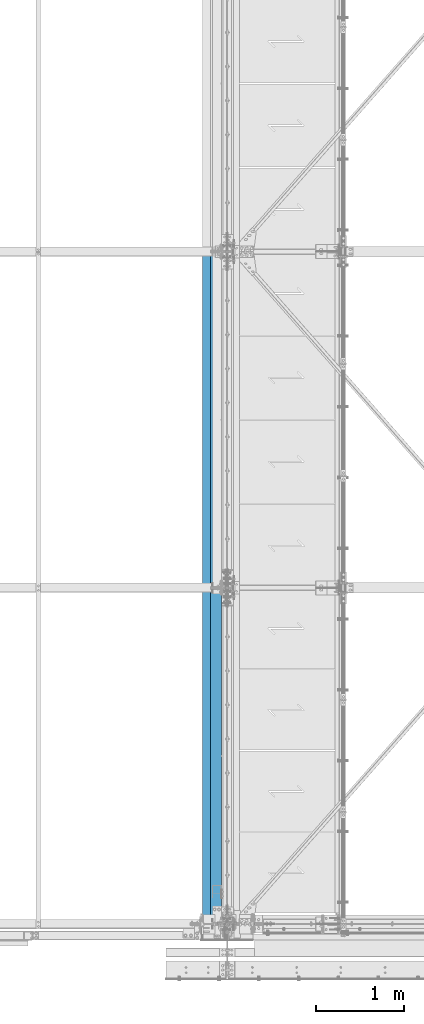
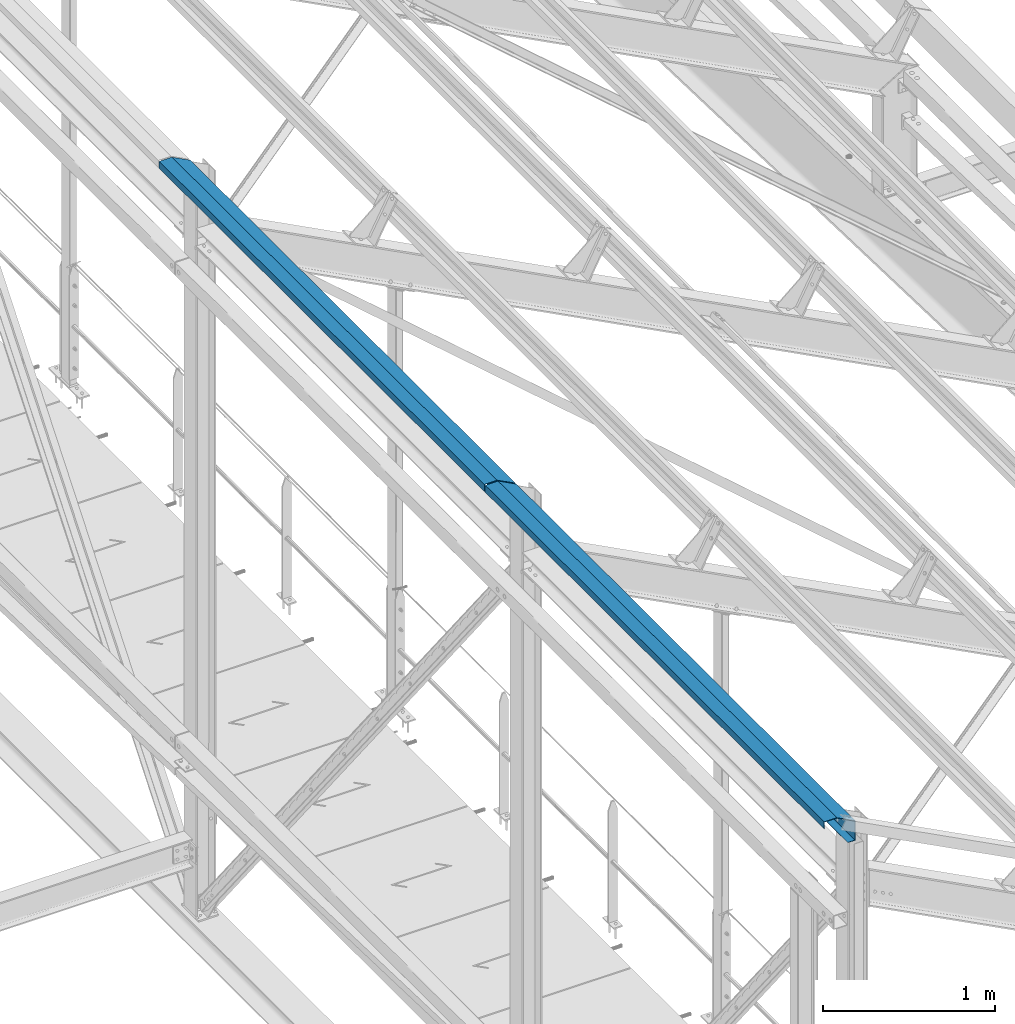
# One storey, part 344 of 496: 2 beams, 2 elements without a shape of their own.
"""IFC2X3 building model written with IfcOpenShell, lengths in millimetres."""

from ifc_helpers import new_model, si_unit, frame, origin_with_axes, place, context, subcontext, project, spatial, faceted_brep, material, type_object, element, aggregate, save


model = new_model("IFC2X3")

# Units and contexts
model_context = context("Model", 3, precision=1e-05, world=origin_with_axes())
body_context = subcontext(model_context, "Body", "Model", "MODEL_VIEW")
ifc_project = project(units=[si_unit("LENGTHUNIT", "METRE", prefix="MILLI"), si_unit("AREAUNIT", "SQUARE_METRE"), si_unit("VOLUMEUNIT", "CUBIC_METRE"), si_unit("MASSUNIT", "GRAM", prefix="KILO"), si_unit("TIMEUNIT", "SECOND"), si_unit("PLANEANGLEUNIT", "RADIAN"), si_unit("SOLIDANGLEUNIT", "STERADIAN"), si_unit("THERMODYNAMICTEMPERATUREUNIT", "DEGREE_CELSIUS"), si_unit("LUMINOUSINTENSITYUNIT", "LUMEN")], contexts=[model_context])

# Site, building, storey
site_placement = place(None, origin_with_axes())
site = spatial("IfcSite", under=ifc_project, at=site_placement, CompositionType="ELEMENT")
building_placement = place(site_placement, origin_with_axes())
building = spatial("IfcBuilding", under=site, at=building_placement, Name="Undefined", CompositionType="ELEMENT")
storey_placement = place(building_placement, origin_with_axes())
storey = spatial("IfcBuildingStorey", under=building, at=storey_placement, Name="Undefined", CompositionType="ELEMENT", Elevation=0.0)

# Assembly, beam
assembly_1_placement = place(storey_placement, origin_with_axes())
assembly_1 = element("IfcElementAssembly", 1, at=assembly_1_placement, inside=storey, Name="SHED", AssemblyPlace="NOTDEFINED", PredefinedType="NOTDEFINED")
ifc_material = material(Name="Undefined/S235-E24")
beam_type_1 = type_object("IfcBeamType", PredefinedType="NOTDEFINED")
beam_1_placement = place(assembly_1_placement, frame((12404.99999895, 5699.99999584194, 12628.7260697644), z_axis=(0.0, 1.0, 0.0), x_axis=(0.0, 0.0, 1.0)))
beam_1 = element("IfcBeam", 2, at=beam_1_placement, type_object=beam_type_1, material=ifc_material, Name="SHED", context=body_context, shape_type="Brep", body=[
    faceted_brep([(-3.49427864421159e-08, -1.49999999999636, -1895.0), (-3.52956703864038e-08, -1.5, 1895.0), (3.49573383573443e-08, 1.5, 1895.0), (3.53102223016322e-08, 1.5, -1895.0), (47.0000011861484, 1.499998899395, 1895.0), (47.0000011898519, 1.49999889939863, -1895.0), (50.0000011927114, -1.50000117085074, -1895.0), (50.0000011890152, -1.50000117085438, 1895.0), (47.0, 83.711228987213, 1895.0), (47.0, 83.711228987213, -1895.0), (50.0, 84.4485168457013, -1895.0), (50.0, 84.4485168457013, 1895.0), (-16.7103107286657, 205.5, 1895.0), (-16.7103107286657, 205.5, -1895.0), (-14.8939838409424, 208.5, -1895.0), (-14.8939838409424, 208.5, 1895.0), (-151.893997192383, 205.5, 1895.0), (-151.893997192383, 205.5, -1895.0), (-154.893997192383, 208.5, -1895.0), (-154.893997192383, 208.5, 1895.0), (-151.893997192383, 158.5, 1895.0), (-151.893997192383, 158.5, -1895.0), (-154.893997192383, 158.5, 1895.0), (-154.893997192383, 158.5, -1895.0)], [[[0, 1, 2, 3]], [[3, 2, 4, 5]], [[1, 0, 6, 7]], [[5, 4, 8, 9]], [[7, 6, 10, 11]], [[9, 8, 12, 13]], [[11, 10, 14, 15]], [[13, 12, 16, 17]], [[15, 14, 18, 19]], [[17, 16, 20, 21]], [[16, 12, 8, 4, 2, 1, 7, 11, 15, 19, 22, 20]], [[19, 18, 23, 22]], [[18, 14, 10, 6, 0, 3, 5, 9, 13, 17, 21, 23]], [[22, 23, 21, 20]]]),
])
aggregate(assembly_1, [beam_1])

assembly_2_placement = place(storey_placement, origin_with_axes())
assembly_2 = element("IfcElementAssembly", 3, at=assembly_2_placement, inside=storey, Name="SHED", AssemblyPlace="NOTDEFINED", PredefinedType="NOTDEFINED")
beam_type_2 = type_object("IfcBeamType", PredefinedType="NOTDEFINED")
beam_2_placement = place(assembly_2_placement, frame((12404.99999895, 1819.99999584194, 12628.7260697675), z_axis=(0.0, -1.0, 0.0), x_axis=(0.0, 0.0, 1.0)))
beam_2 = element("IfcBeam", 4, at=beam_2_placement, type_object=beam_type_2, material=ifc_material, Name="SHED", context=body_context, shape_type="Brep", body=[
    faceted_brep([(-4.57293936051428e-09, -1.5, -1975.0), (-2.82670953311026e-09, -1.49999999999636, 1975.0), (4.57293936051428e-09, 1.50000000000364, 1975.0), (2.82307155430317e-09, 1.50000000000364, -1975.0), (50.0, 1.5, 1975.0), (50.0, 1.5, -1975.0), (47.0, -1.5, -1975.0), (47.0, -1.5, 1975.0), (50.0, -84.4485168457013, 1975.0), (50.0, -84.4485168457013, -1975.0), (47.0, -83.711228987213, -1975.0), (47.0, -83.711228987213, 1975.0), (-14.8939838409424, -208.5, 1975.0), (-14.8939838409424, -208.5, -1975.0), (-16.7103107286657, -205.5, -1975.0), (-16.7103107286657, -205.5, 1975.0), (-154.893997192383, -208.5, 1975.0), (-154.893997192383, -208.5, -1975.0), (-151.893997192383, -205.5, -1975.0), (-151.893997192383, -205.5, 1975.0), (-154.893997192383, -158.5, 1975.0), (-154.893997192383, -158.5, -1975.0), (-151.893997192383, -158.5, 1975.0), (-151.893997192383, -158.5, -1975.0)], [[[0, 1, 2, 3]], [[3, 2, 4, 5]], [[1, 0, 6, 7]], [[5, 4, 8, 9]], [[7, 6, 10, 11]], [[9, 8, 12, 13]], [[11, 10, 14, 15]], [[13, 12, 16, 17]], [[15, 14, 18, 19]], [[17, 16, 20, 21]], [[16, 12, 8, 4, 2, 1, 7, 11, 15, 19, 22, 20]], [[19, 18, 23, 22]], [[18, 14, 10, 6, 0, 3, 5, 9, 13, 17, 21, 23]], [[22, 23, 21, 20]]]),
])
aggregate(assembly_2, [beam_2])

save(model, "model.ifc")
